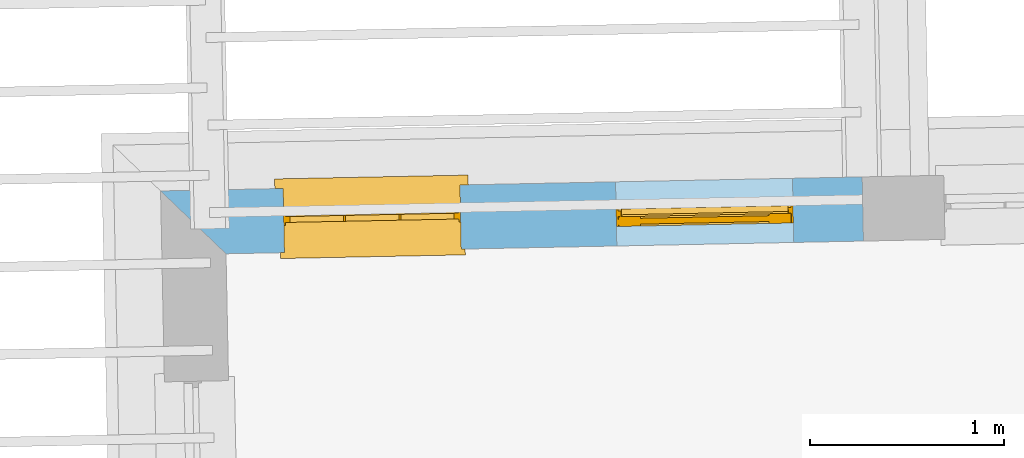
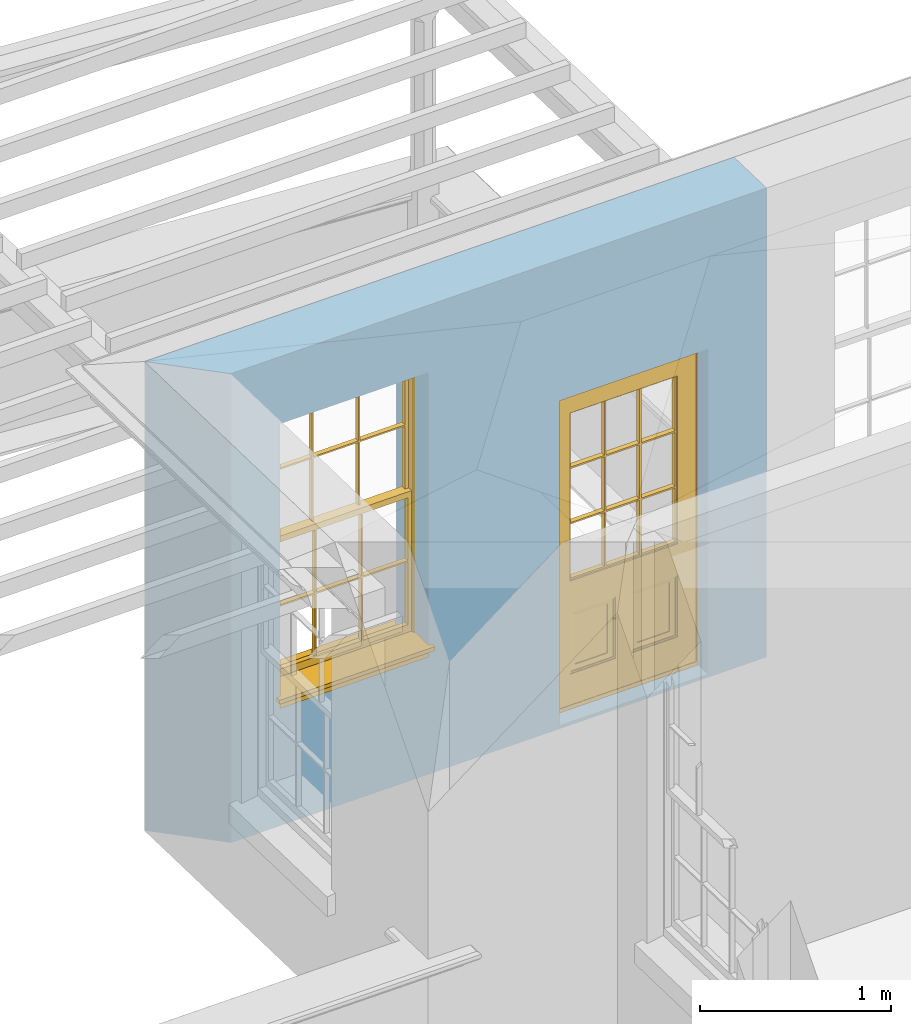
# One storey, part 7 of 11: 1 door, 1 window, 2 openings, plus 1 element that does not belong to this part.
"""IFC2X3 building model written with IfcOpenShell, lengths in metres."""

from ifc_helpers import new_model, si_unit, frame, origin, place, context, subcontext, project, spatial, polyline, outline, extrude, faceted_brep, material, layer, layer_set, layer_usage, element, fill, save


model = new_model("IFC2X3")

# Units and contexts
model_context = context("Model", 3, world=origin())
body_context = subcontext(model_context, "Body", "Model", "MODEL_VIEW")
ifc_project = project(units=[si_unit("PLANEANGLEUNIT", "RADIAN"), si_unit("MASSUNIT", "GRAM", prefix="KILO"), si_unit("FORCEUNIT", "NEWTON", prefix="KILO"), si_unit("LENGTHUNIT", "METRE")], contexts=[model_context])

# Site, building, storey
site_placement = place(None, origin())
site = spatial("IfcSite", under=ifc_project, at=site_placement, CompositionType="ELEMENT")
building_placement = place(None, origin())
building = spatial("IfcBuilding", under=site, at=building_placement, Name="Building plot-11", CompositionType="ELEMENT")
storey_placement = place(None, frame((0.0, 0.0, 5.3)))
storey = spatial("IfcBuildingStorey", under=building, at=storey_placement, Name="Floor 1", CompositionType="ELEMENT", Elevation=5.3)

# Wall, openings, door, window
ifc_material = material(Name="Masonry")
ifc_layer = layer(ifc_material, 0.33, ventilated=False)
ifc_layer_set = layer_set([ifc_layer], Name="My Wall")
ifc_layer_usage = layer_usage(ifc_layer_set, "AXIS2", "NEGATIVE", 0.08)
wall_placement = place(storey_placement, origin())
wall = element("IfcWallStandardCase", 1, at=wall_placement, inside=storey, material=ifc_layer_usage, Name="exterior", context=body_context, shape_type="SweptSolid", body=[
    extrude(outline(polyline([(62.0774340593141, 22.6503225560195), (62.0708365057897, 22.9802565983485), (58.4633191417055, 22.9081185772706), (58.7998507375589, 22.5847820884662), (62.0774340593141, 22.6503225560195)])), origin(), (0.0, 0.0, 1.0), 3.0),
])
opening_1_placement = place(storey_placement, frame((0.0, 0.0, 0.0199999999999996)))
opening_1 = element("IfcOpeningElement", 2, at=opening_1_placement, cuts=wall, Name="Opening", ObjectType="Opening", context=body_context, shape_type="SweptSolid", body=[
    extrude(outline(polyline([(61.7126695585811, 22.9730944831929), (60.802851441856, 22.9549012295347), (60.8094489953804, 22.6249671872058), (61.7192671121056, 22.643160440864), (61.7126695585811, 22.9730944831929)])), origin(), (0.0, 0.0, 1.0), 2.08),
])
opening_2_placement = place(storey_placement, frame((0.0, 0.0, 0.75)))
opening_2 = element("IfcOpeningElement", 3, at=opening_2_placement, cuts=wall, Name="Opening", ObjectType="Opening", context=body_context, shape_type="SweptSolid", body=[
    extrude(outline(polyline([(60.0030113392404, 22.9389071603846), (59.0931932225153, 22.9207139067264), (59.0997907760397, 22.5907798643974), (60.0096088927649, 22.6089731180557), (60.0030113392404, 22.9389071603846)])), origin(), (0.0, 0.0, 1.0), 1.82),
])
door_placement = place(storey_placement, frame((61.7176677051905, 22.7231444511256, 0.0199999999999996), z_axis=(0.0, 0.0, 1.0), x_axis=(-0.90981811672517, -0.0181932536582394, 0.0)))
door = element("IfcDoor", 4, at=door_placement, inside=storey, Name="circulation outside door", OverallHeight=2.08, OverallWidth=0.91, context=body_context, shape_type="Brep", held_by="IfcProductRepresentation", body=[
    faceted_brep([(0.545, -0.055, 0.265), (0.745, -0.055, 0.265), (0.745, -0.05, 0.265), (0.545, -0.05, 0.265), (0.745, -0.05, 0.58), (0.545, -0.05, 0.58), (0.545, -0.055, 0.58), (0.515, -0.06, 0.235), (0.775, -0.06, 0.235), (0.745, -0.055, 0.58), (0.515, -0.06, 0.61), (0.515, -0.065, 0.235), (0.775, -0.065, 0.235), (0.775, -0.06, 0.61), (0.515, -0.065, 0.61), (0.785, -0.065, 0.225), (0.505, -0.065, 0.225), (0.775, -0.065, 0.61), (0.505, -0.065, 0.62), (0.785, -0.065, 0.62), (0.505, -0.07, 0.225), (0.785, -0.07, 0.225), (0.505, -0.07, 0.62), (0.785, -0.07, 0.62), (0.883, -0.07, 0.075), (0.898, -0.07, 0.075), (0.405, -0.07, 0.62), (0.405, -0.07, 0.225), (0.027, -0.07, 0.075), (0.785, -0.07, 0.82), (0.125, -0.07, 0.82), (0.405, -0.065, 0.62), (0.405, -0.065, 0.225), (0.898, -0.07, 2.068), (0.027, -0.08, 0.075), (0.883, -0.08, 0.075), (0.125, -0.07, 0.225), (0.012, -0.07, 0.075), (0.785, -0.06, 0.82), (0.125, -0.06, 0.82), (0.125, -0.07, 0.62), (0.125, -0.065, 0.62), (0.395, -0.065, 0.61), (0.395, -0.065, 0.235), (0.125, -0.065, 0.225), (0.785, -0.07, 1.895), (0.027, -0.11, 0.045), (0.883, -0.11, 0.045), (0.558333, -0.06, 0.83), (0.351667, -0.06, 0.83), (0.125, -0.07, 1.895), (0.125, -0.06, 1.895), (0.785, -0.06, 1.895), (0.012, -0.07, 2.068), (0.135, -0.065, 0.61), (0.395, -0.06, 0.61), (0.395, -0.06, 0.235), (0.135, -0.065, 0.235), (0.027, -0.11, 0.027), (0.883, -0.11, 0.027), (0.568333, -0.06, 0.83), (0.558333, -0.03, 0.83), (0.351667, -0.03, 0.83), (0.341667, -0.06, 0.83), (0.135, -0.06, 1.185), (0.135, -0.06, 1.53), (0.775, -0.06, 1.53), (0.775, -0.06, 1.185), (0.135, -0.06, 0.61), (0.365, -0.055, 0.58), (0.365, -0.055, 0.265), (0.135, -0.06, 0.235), (0.568333, -0.06, 1.175), (0.558333, -0.06, 1.175), (0.775, -0.06, 0.83), (0.558333, -0.03, 1.175), (0.785, -0.03, 0.82), (0.125, -0.03, 0.82), (0.351667, -0.03, 1.175), (0.351667, -0.06, 1.175), (0.341667, -0.06, 1.175), (0.135, -0.06, 0.83), (0.135, -0.06, 1.175), (0.135, -0.03, 1.185), (0.135, -0.03, 1.53), (0.135, -0.06, 1.54), (0.351667, -0.06, 1.885), (0.558333, -0.06, 1.885), (0.775, -0.03, 1.53), (0.775, -0.03, 1.185), (0.775, -0.06, 1.175), (0.775, -0.06, 1.54), (0.165, -0.055, 0.58), (0.365, -0.05, 0.58), (0.365, -0.05, 0.265), (0.165, -0.055, 0.265), (0.568333, -0.03, 0.83), (0.568333, -0.03, 1.175), (0.568333, -0.06, 1.185), (0.558333, -0.06, 1.185), (0.775, -0.03, 0.83), (0.785, -0.02, 0.82), (0.125, -0.02, 0.82), (0.341667, -0.03, 0.83), (0.341667, -0.03, 1.175), (0.351667, -0.06, 1.185), (0.341667, -0.06, 1.185), (0.135, -0.03, 0.83), (0.341667, -0.03, 1.185), (0.125, -0.03, 1.895), (0.341667, -0.03, 1.53), (0.341667, -0.06, 1.53), (0.135, -0.06, 1.885), (0.341667, -0.06, 1.54), (0.341667, -0.06, 1.885), (0.558333, -0.03, 1.885), (0.351667, -0.03, 1.885), (0.568333, -0.06, 1.885), (0.785, -0.03, 1.895), (0.568333, -0.03, 1.185), (0.568333, -0.06, 1.53), (0.568333, -0.03, 1.53), (0.568333, -0.06, 1.54), (0.775, -0.06, 1.885), (0.165, -0.05, 0.58), (0.165, -0.05, 0.265), (0.775, -0.03, 1.175), (0.558333, -0.06, 1.53), (0.351667, -0.03, 1.185), (0.558333, -0.03, 1.185), (0.505, -0.02, 0.62), (0.405, -0.02, 0.62), (0.125, -0.02, 1.895), (0.785, -0.02, 1.895), (0.351667, -0.06, 1.53), (0.135, -0.03, 1.175), (0.135, -0.03, 1.54), (0.341667, -0.03, 1.54), (0.135, -0.03, 1.885), (0.351667, -0.06, 1.54), (0.558333, -0.03, 1.54), (0.558333, -0.06, 1.54), (0.351667, -0.03, 1.54), (0.775, -0.03, 1.54), (0.568333, -0.03, 1.54), (0.775, -0.03, 1.885), (0.558333, -0.03, 1.53), (0.405, -0.02, 0.225), (0.505, -0.02, 0.225), (0.125, -0.02, 0.62), (0.785, -0.02, 0.62), (0.012, -0.02, 2.068), (0.898, -0.02, 2.068), (0.351667, -0.03, 1.53), (0.341667, -0.03, 1.885), (0.568333, -0.03, 1.885), (0.405, -0.025, 0.225), (0.405, -0.025, 0.62), (0.505, -0.025, 0.62), (0.505, -0.025, 0.225), (0.898, -0.02, 0.027), (0.012, -0.02, 0.027), (0.125, -0.025, 0.62), (0.785, -0.025, 0.62), (0.395, -0.025, 0.235), (0.395, -0.025, 0.61), (0.125, -0.02, 0.225), (0.125, -0.025, 0.225), (0.515, -0.025, 0.61), (0.515, -0.025, 0.235), (0.785, -0.02, 0.225), (0.785, -0.025, 0.225), (0.135, -0.025, 0.61), (0.775, -0.025, 0.61), (0.135, -0.025, 0.235), (0.395, -0.03, 0.235), (0.395, -0.03, 0.61), (0.515, -0.03, 0.61), (0.515, -0.03, 0.235), (0.775, -0.025, 0.235), (0.135, -0.03, 0.61), (0.775, -0.03, 0.61), (0.135, -0.03, 0.235), (0.365, -0.035, 0.265), (0.365, -0.035, 0.58), (0.545, -0.035, 0.58), (0.545, -0.035, 0.265), (0.775, -0.03, 0.235), (0.165, -0.035, 0.58), (0.745, -0.035, 0.58), (0.165, -0.035, 0.265), (0.365, -0.04, 0.58), (0.365, -0.04, 0.265), (0.545, -0.04, 0.58), (0.545, -0.04, 0.265), (0.745, -0.035, 0.265), (0.165, -0.04, 0.58), (0.745, -0.04, 0.58), (0.165, -0.04, 0.265), (0.745, -0.04, 0.265), (0.885, -0.072, 0.025), (0.025, -0.072, 0.025), (0.025, -0.1, 0.025), (0.885, -0.1, 0.025), (0.9, -0.02, 0.025), (0.01, -0.02, 0.025), (0.9, -0.072, 0.025), (0.91, -0.02, 0.0), (0.0, -0.02, 0.0), (0.01, -0.072, 0.025), (0.9, -0.072, 2.07), (0.9, -0.02, 2.07), (0.885, -0.072, 2.055), (0.91, -0.02, 2.08), (0.01, -0.02, 2.07), (0.0, -0.02, 2.08), (0.01, -0.072, 2.07), (0.025, -0.072, 2.055), (0.0, -0.15, 2.08), (0.91, -0.15, 2.08), (0.01, -0.15, 2.07), (0.9, -0.15, 2.07), (0.01, -0.1, 2.07), (0.9, -0.1, 2.07), (0.0, -0.15, 0.0), (0.91, -0.15, 0.0), (0.01, -0.15, 0.025), (0.9, -0.15, 0.025), (0.01, -0.1, 0.025), (0.025, -0.1, 2.055), (0.9, -0.1, 0.025), (0.885, -0.1, 2.055), (0.898, -0.07, 0.027), (0.012, -0.07, 0.027), (0.883, -0.07, 0.027), (0.027, -0.07, 0.027)], [[[0, 1, 2, 3]], [[2, 4, 5, 3]], [[0, 3, 5, 6]], [[1, 0, 7, 8]], [[9, 4, 2, 1]], [[9, 6, 5, 4]], [[0, 6, 10, 7]], [[8, 7, 11, 12]], [[8, 13, 9, 1]], [[13, 10, 6, 9]], [[7, 10, 14, 11]], [[15, 12, 11, 16]], [[12, 17, 13, 8]], [[17, 14, 10, 13]], [[18, 16, 11, 14]], [[15, 19, 17, 12]], [[15, 16, 20, 21]], [[14, 17, 19, 18]], [[16, 18, 22, 20]], [[21, 23, 19, 15]], [[24, 25, 21, 20]], [[23, 22, 18, 19]], [[20, 22, 26, 27]], [[23, 21, 25]], [[28, 24, 20, 27]], [[22, 23, 29]], [[29, 30, 26, 22]], [[27, 26, 31, 32]], [[23, 25, 33, 29]], [[34, 35, 24, 28]], [[28, 27, 36, 37]], [[38, 39, 30, 29]], [[26, 30, 40]], [[26, 40, 41, 31]], [[42, 43, 32, 31]], [[32, 44, 36, 27]], [[33, 45, 29]], [[46, 47, 35, 34]], [[36, 40, 37]], [[39, 38, 48, 49]], [[50, 30, 39, 51]], [[29, 45, 52, 38]], [[53, 37, 40, 30]], [[44, 41, 40, 36]], [[31, 41, 54, 42]], [[43, 42, 55, 56]], [[57, 44, 32, 43]], [[50, 45, 33, 53]], [[47, 46, 58, 59]], [[60, 48, 38]], [[49, 48, 61, 62]], [[49, 63, 39]], [[50, 53, 30]], [[51, 39, 64, 65]], [[45, 50, 51, 52]], [[66, 67, 38, 52]], [[57, 54, 41, 44]], [[42, 54, 68, 55]], [[56, 55, 69, 70]], [[56, 71, 57, 43]], [[60, 72, 73, 48]], [[60, 38, 74]], [[48, 73, 75, 61]], [[76, 77, 62, 61]], [[62, 78, 79, 49]], [[49, 79, 80, 63]], [[63, 81, 39]], [[82, 64, 39]], [[65, 64, 83, 84]], [[85, 51, 65]], [[52, 51, 86, 87]], [[88, 89, 67, 66]], [[90, 38, 67]], [[91, 66, 52]], [[71, 68, 54, 57]], [[55, 68, 92, 69]], [[69, 93, 94, 70]], [[70, 95, 71, 56]], [[96, 97, 72, 60]], [[73, 72, 98, 99]], [[74, 38, 90]], [[100, 96, 60, 74]], [[75, 73, 79, 78]], [[61, 75, 97, 96]], [[101, 102, 77, 76]], [[77, 103, 62]], [[96, 76, 61]], [[103, 104, 78, 62]], [[80, 79, 105, 106]], [[63, 80, 104, 103]], [[81, 63, 103, 107]], [[81, 82, 39]], [[106, 64, 82, 80]], [[106, 108, 83, 64]], [[84, 83, 77, 109]], [[110, 111, 65, 84]], [[112, 51, 85]], [[113, 85, 65, 111]], [[114, 86, 51]], [[115, 87, 86, 116]], [[117, 52, 87]], [[118, 76, 89, 88]], [[119, 98, 67, 89]], [[120, 121, 88, 66]], [[67, 98, 72, 90]], [[91, 122, 120, 66]], [[91, 52, 123]], [[95, 92, 68, 71]], [[69, 92, 124, 93]], [[94, 93, 124, 125]], [[94, 125, 95, 70]], [[72, 97, 126, 90]], [[127, 99, 98, 120]], [[99, 105, 79, 73]], [[74, 90, 126, 100]], [[96, 100, 76]], [[128, 129, 75, 78]], [[97, 75, 129, 119]], [[130, 131, 102, 101]], [[109, 77, 102, 132]], [[133, 101, 76, 118]], [[77, 107, 103]], [[78, 104, 108, 128]], [[111, 106, 105, 134]], [[104, 80, 82, 135]], [[107, 135, 82, 81]], [[110, 108, 106, 111]], [[104, 135, 83, 108]], [[83, 135, 77]], [[136, 84, 109]], [[110, 84, 136, 137]], [[114, 51, 112]], [[85, 136, 138, 112]], [[113, 137, 136, 85]], [[111, 134, 139, 113]], [[86, 114, 113, 139]], [[140, 141, 87, 115]], [[139, 142, 116, 86]], [[109, 118, 115, 116]], [[117, 123, 52]], [[117, 87, 141, 122]], [[126, 89, 76]], [[143, 118, 88]], [[120, 98, 119, 121]], [[119, 89, 126, 97]], [[144, 143, 88, 121]], [[144, 122, 91, 143]], [[127, 120, 122, 141]], [[143, 91, 123, 145]], [[124, 92, 95, 125]], [[146, 129, 99, 127]], [[99, 129, 128, 105]], [[100, 126, 76]], [[121, 119, 129, 146]], [[147, 131, 130, 148]], [[131, 149, 102]], [[130, 101, 150]], [[102, 151, 132]], [[118, 109, 132, 133]], [[101, 133, 152]], [[107, 77, 135]], [[153, 128, 108, 110]], [[134, 105, 128, 153]], [[109, 138, 136]], [[153, 110, 137, 142]], [[154, 114, 112, 138]], [[137, 113, 114, 154]], [[141, 139, 134, 127]], [[141, 140, 142, 139]], [[144, 140, 115, 155]], [[142, 137, 154, 116]], [[155, 115, 118]], [[116, 154, 109]], [[117, 155, 145, 123]], [[122, 144, 155, 117]], [[143, 145, 118]], [[121, 146, 140, 144]], [[146, 127, 134, 153]], [[156, 157, 131, 147]], [[148, 130, 158, 159]], [[148, 160, 161, 147]], [[157, 162, 149, 131]], [[161, 151, 102, 149]], [[101, 152, 160, 150]], [[163, 158, 130, 150]], [[151, 152, 133, 132]], [[154, 138, 109]], [[142, 140, 146, 153]], [[145, 155, 118]], [[157, 156, 164, 165]], [[147, 166, 167, 156]], [[168, 169, 159, 158]], [[170, 148, 159, 171]], [[148, 170, 160]], [[166, 147, 161]], [[172, 162, 157, 165]], [[166, 149, 162, 167]], [[166, 161, 149]], [[150, 160, 170]], [[163, 173, 168, 158]], [[171, 163, 150, 170]], [[174, 164, 156, 167]], [[175, 176, 165, 164]], [[169, 168, 177, 178]], [[171, 159, 169, 179]], [[167, 162, 172, 174]], [[176, 180, 172, 165]], [[179, 173, 163, 171]], [[181, 177, 168, 173]], [[164, 174, 182, 175]], [[183, 184, 176, 175]], [[178, 177, 185, 186]], [[179, 169, 178, 187]], [[174, 172, 180, 182]], [[184, 188, 180, 176]], [[187, 181, 173, 179]], [[189, 185, 177, 181]], [[175, 182, 190, 183]], [[191, 184, 183, 192]], [[185, 193, 194, 186]], [[187, 178, 186, 195]], [[182, 180, 188, 190]], [[191, 196, 188, 184]], [[195, 189, 181, 187]], [[197, 193, 185, 189]], [[183, 190, 198, 192]], [[198, 196, 191, 192]], [[194, 193, 197, 199]], [[195, 186, 194, 199]], [[188, 196, 198, 190]], [[197, 189, 195, 199]], [[200, 201, 202, 203]], [[201, 200, 204, 205]], [[206, 204, 200]], [[204, 207, 208, 205]], [[209, 201, 205]], [[210, 211, 204, 206]], [[206, 200, 212, 210]], [[211, 213, 207, 204]], [[214, 205, 208, 215]], [[216, 217, 201, 209]], [[205, 214, 216, 209]], [[216, 214, 211, 210]], [[210, 212, 217, 216]], [[214, 215, 213, 211]], [[218, 219, 213, 215]], [[219, 218, 220, 221]], [[221, 220, 222, 223]], [[215, 208, 224, 218]], [[225, 224, 208, 207]], [[224, 226, 220, 218]], [[224, 225, 227, 226]], [[219, 225, 207, 213]], [[228, 222, 220, 226]], [[219, 221, 227, 225]], [[226, 227, 203, 202]], [[202, 229, 222, 228]], [[228, 226, 202]], [[227, 221, 223, 230]], [[230, 203, 227]], [[217, 229, 202, 201]], [[231, 223, 222, 229]], [[230, 223, 231, 203]], [[231, 229, 217, 212]], [[212, 200, 203, 231]], [[33, 152, 151, 53]], [[25, 160, 152, 33]], [[161, 37, 53, 151]], [[232, 160, 25]], [[161, 233, 37]], [[160, 232, 234]], [[24, 234, 232, 25]], [[233, 161, 235]], [[37, 233, 235, 28]], [[161, 160, 234, 235]], [[35, 47, 234, 24]], [[28, 235, 46, 34]], [[58, 235, 234, 59]], [[59, 234, 47]], [[58, 46, 235]]]),
])
fill(opening_1, door)
window_placement = place(storey_placement, frame((60.0080094858498, 22.6889571283172, 0.75), z_axis=(0.0, 0.0, 1.0), x_axis=(-0.90981811672517, -0.018193253658243, 0.0)))
window = element("IfcWindow", 5, at=window_placement, inside=storey, Name="circulation outside window", OverallHeight=1.82, OverallWidth=0.91, context=body_context, shape_type="Brep", held_by="IfcProductRepresentation", body=[
    faceted_brep([(0.033125, -0.105, 0.975209), (0.01, -0.105, 0.975209), (0.033125, -0.105, 1.376042), (0.876875, -0.105, 0.975209), (0.876875, -0.105, 1.376042), (0.9, -0.105, 0.975209), (0.876875, -0.105, 1.386042), (0.876875, -0.105, 1.786875), (0.9, -0.105, 1.81), (0.033125, -0.105, 1.786875), (0.033125, -0.105, 1.386042), (0.01, -0.105, 1.81), (0.876875, -0.135, 1.376042), (0.876875, -0.135, 0.975209), (0.9, -0.135, 0.937083), (0.033125, -0.135, 1.786875), (0.01, -0.135, 1.81), (0.033125, -0.135, 1.386042), (0.01, -0.135, 0.937083), (0.033125, -0.135, 0.975209), (0.033125, -0.135, 1.376042), (0.876875, -0.135, 1.786875), (0.876875, -0.135, 1.386042), (0.9, -0.135, 1.81), (0.033125, -0.105, 0.937083), (0.01, -0.105, 0.937083), (0.033125, -0.105, 0.53625), (0.876875, -0.105, 0.937083), (0.876875, -0.105, 0.53625), (0.9, -0.105, 0.937083), (0.876875, -0.105, 0.52625), (0.876875, -0.105, 0.125417), (0.9, -0.105, 0.077167), (0.033125, -0.105, 0.125417), (0.033125, -0.105, 0.52625), (0.01, -0.105, 0.077167), (-0.0425, -0.25, 0.01), (-0.0425, -0.3, 0.001667), (0.0, -0.25, 0.01), (0.9525, -0.25, 0.01), (0.91, -0.25, 0.01), (0.9525, -0.3, 0.001667), (-0.02, 0.08, 0.077167), (0.0, 0.08, 0.077167), (-0.02, 0.11, 0.077167), (0.0, -0.06, 0.077167), (0.01, -0.06, 0.077167), (0.91, -0.06, 0.077167), (0.91, 0.08, 0.077167), (0.9, -0.06, 0.077167), (0.93, 0.08, 0.077167), (0.93, 0.11, 0.077167), (0.01, -0.075, 0.975209), (0.9, -0.075, 0.975209), (0.876875, -0.075, 0.125417), (0.876875, -0.075, 0.52625), (0.9, -0.075, 0.077167), (0.876875, -0.075, 0.53625), (0.876875, -0.075, 0.937083), (0.033125, -0.075, 0.125417), (0.01, -0.075, 0.077167), (0.033125, -0.075, 0.52625), (0.033125, -0.075, 0.937083), (0.033125, -0.075, 0.53625), (-0.02, 0.08, 0.052167), (-0.02, 0.11, 0.052167), (0.93, 0.11, 0.052167), (0.93, 0.08, 0.052167), (0.91, 0.08, 0.052167), (0.0, 0.08, 0.052167), (0.91, -0.15, 0.026667), (0.0, -0.15, 0.026667), (-0.0425, -0.3, -0.123333), (0.9525, -0.3, -0.123333), (-0.0425, -0.25, -0.123333), (0.9525, -0.25, -0.123333), (0.01, -0.06, 1.81), (0.9, -0.06, 1.81), (0.0, -0.06, 1.82), (0.91, -0.06, 1.82), (0.01, -0.15, 0.077167), (0.9, -0.15, 0.077167), (0.592292, -0.105, 0.125417), (0.592292, -0.075, 0.125417), (0.317708, -0.075, 0.125417), (0.317708, -0.105, 0.125417), (0.592292, -0.105, 0.53625), (0.317708, -0.105, 0.53625), (0.317708, -0.105, 0.52625), (0.592292, -0.105, 0.52625), (0.592292, -0.075, 0.53625), (0.317708, -0.075, 0.53625), (0.592292, -0.135, 1.386042), (0.592292, -0.105, 1.386042), (0.317708, -0.105, 1.386042), (0.317708, -0.135, 1.386042), (0.317708, -0.135, 1.376042), (0.592292, -0.135, 1.376042), (0.317708, -0.105, 1.376042), (0.592292, -0.105, 1.376042), (0.602292, -0.135, 1.376042), (0.592292, -0.135, 0.975209), (0.602292, -0.135, 0.975209), (0.602292, -0.105, 0.975209), (0.592292, -0.105, 0.975209), (0.602292, -0.105, 1.376042), (0.602292, -0.075, 0.53625), (0.602292, -0.105, 0.53625), (0.317708, -0.075, 0.52625), (0.307708, -0.075, 0.125417), (0.307708, -0.075, 0.52625), (0.602292, -0.075, 0.52625), (0.602292, -0.075, 0.125417), (0.592292, -0.075, 0.52625), (0.307708, -0.075, 0.53625), (0.317708, -0.075, 0.937083), (0.307708, -0.075, 0.937083), (0.602292, -0.075, 0.937083), (0.592292, -0.075, 0.937083), (0.307708, -0.105, 0.52625), (0.307708, -0.105, 0.125417), (0.307708, -0.105, 0.53625), (0.307708, -0.105, 0.937083), (0.592292, -0.105, 0.937083), (0.317708, -0.105, 0.937083), (0.602292, -0.105, 0.937083), (0.602292, -0.105, 0.52625), (0.602292, -0.105, 0.125417), (0.307708, -0.135, 1.386042), (0.307708, -0.135, 1.376042), (0.307708, -0.135, 0.975209), (0.317708, -0.135, 0.975209), (0.317708, -0.135, 1.786875), (0.307708, -0.135, 1.786875), (0.602292, -0.135, 1.786875), (0.592292, -0.135, 1.786875), (0.602292, -0.135, 1.386042), (0.602292, -0.105, 1.386042), (0.307708, -0.105, 1.386042), (0.307708, -0.105, 1.786875), (0.317708, -0.105, 1.786875), (0.592292, -0.105, 1.786875), (0.602292, -0.105, 1.786875), (0.307708, -0.105, 1.376042), (0.317708, -0.105, 0.975209), (0.307708, -0.105, 0.975209), (0.91, -0.15, 1.82), (0.9, -0.15, 1.81), (0.01, -0.15, 1.81), (0.0, -0.15, 1.82), (0.91, -0.25, 0.0), (0.0, -0.25, 0.0), (0.91, 0.08, 0.0), (0.0, 0.08, 0.0)], [[[0, 1, 2]], [[3, 4, 5]], [[6, 7, 8]], [[9, 10, 11]], [[12, 13, 14]], [[15, 16, 17]], [[18, 19, 20]], [[21, 22, 23]], [[24, 25, 26]], [[27, 28, 29]], [[30, 31, 32]], [[33, 34, 35]], [[14, 27, 29]], [[25, 24, 18]], [[36, 37, 38]], [[39, 40, 41]], [[42, 43, 44]], [[45, 46, 43]], [[47, 48, 49]], [[50, 51, 48]], [[1, 0, 52]], [[5, 53, 3]], [[54, 55, 56]], [[57, 58, 53]], [[59, 60, 61]], [[62, 63, 52]], [[48, 43, 46, 49]], [[51, 44, 43, 48]], [[64, 42, 44, 65]], [[65, 44, 51, 66]], [[66, 51, 50, 67]], [[65, 66, 68, 69]], [[60, 56, 49, 46]], [[70, 71, 38, 40]], [[37, 41, 40, 38]], [[37, 72, 73, 41]], [[74, 75, 73, 72]], [[8, 11, 76, 77]], [[76, 78, 79, 77]], [[32, 35, 80, 81]], [[81, 80, 71, 70]], [[82, 83, 84, 85]], [[86, 87, 88, 89]], [[86, 90, 91, 87]], [[92, 93, 94, 95]], [[92, 95, 96, 97]], [[96, 98, 99, 97]], [[100, 97, 101, 102]], [[103, 104, 99, 105]], [[97, 99, 104, 101]], [[102, 103, 105, 100]], [[28, 57, 106, 107]], [[108, 84, 109, 110]], [[111, 112, 83, 113]], [[114, 110, 61, 63]], [[90, 113, 108, 91]], [[115, 91, 114, 116]], [[117, 106, 90, 118]], [[111, 106, 57, 55]], [[119, 110, 109, 120]], [[34, 61, 110, 119]], [[89, 113, 83, 82]], [[88, 108, 113, 89]], [[85, 84, 108, 88]], [[121, 114, 63, 26]], [[122, 116, 114, 121]], [[123, 118, 90, 86]], [[87, 91, 115, 124]], [[107, 106, 117, 125]], [[126, 111, 55, 30]], [[127, 112, 111, 126]], [[126, 30, 28, 107]], [[88, 119, 120, 85]], [[126, 89, 82, 127]], [[125, 123, 86, 107]], [[121, 26, 34, 119]], [[124, 122, 121, 87]], [[128, 17, 20, 129]], [[96, 129, 130, 131]], [[132, 133, 128, 95]], [[134, 135, 92, 136]], [[100, 12, 22, 136]], [[137, 6, 4, 105]], [[94, 138, 139, 140]], [[137, 93, 141, 142]], [[99, 98, 94, 93]], [[143, 2, 10, 138]], [[144, 145, 143, 98]], [[129, 143, 145, 130]], [[20, 2, 143, 129]], [[131, 144, 98, 96]], [[128, 138, 10, 17]], [[133, 139, 138, 128]], [[135, 141, 93, 92]], [[95, 94, 140, 132]], [[22, 6, 137, 136]], [[136, 137, 142, 134]], [[100, 105, 4, 12]], [[107, 86, 89, 126]], [[106, 111, 113, 90]], [[91, 108, 110, 114]], [[87, 121, 119, 88]], [[97, 100, 136, 92]], [[129, 96, 95, 128]], [[98, 143, 138, 94]], [[105, 99, 93, 137]], [[131, 101, 104, 144]], [[124, 115, 118, 123]], [[132, 140, 141, 135]], [[120, 109, 59, 33]], [[15, 9, 139, 133]], [[134, 142, 7, 21]], [[31, 54, 112, 127]], [[36, 74, 72, 37]], [[39, 41, 73, 75]], [[18, 14, 101, 131]], [[23, 16, 132, 135]], [[83, 56, 60, 84]], [[52, 53, 118, 115]], [[53, 52, 144, 104]], [[11, 8, 141, 140]], [[14, 18, 124, 123]], [[2, 1, 11, 10]], [[8, 5, 4, 6]], [[57, 53, 56, 55]], [[60, 52, 63, 61]], [[26, 25, 35, 34]], [[32, 29, 28, 30]], [[14, 23, 22, 12]], [[18, 20, 17, 16]], [[19, 0, 2, 20]], [[17, 10, 9, 15]], [[12, 4, 3, 13]], [[21, 7, 6, 22]], [[27, 58, 57, 28]], [[30, 55, 54, 31]], [[33, 59, 61, 34]], [[26, 63, 62, 24]], [[5, 8, 77, 53]], [[76, 11, 1, 52]], [[46, 45, 78, 76]], [[49, 77, 79, 47]], [[70, 146, 147, 81]], [[71, 80, 148, 149]], [[19, 130, 145, 0]], [[102, 13, 3, 103]], [[116, 122, 24, 62]], [[29, 32, 81, 14]], [[80, 35, 25, 18]], [[60, 46, 76, 52]], [[77, 49, 56, 53]], [[23, 14, 81, 147]], [[16, 148, 80, 18]], [[35, 85, 120]], [[120, 33, 35]], [[127, 82, 32]], [[32, 31, 127]], [[32, 82, 85, 35]], [[102, 101, 14]], [[14, 13, 102]], [[18, 131, 130]], [[130, 19, 18]], [[134, 21, 23]], [[23, 135, 134]], [[16, 15, 133]], [[133, 132, 16]], [[11, 140, 139]], [[139, 9, 11]], [[142, 141, 8]], [[8, 7, 142]], [[23, 147, 148, 16]], [[146, 149, 148, 147]], [[52, 115, 116]], [[116, 62, 52]], [[118, 53, 117]], [[58, 117, 53]], [[27, 125, 117, 58]], [[56, 83, 112]], [[112, 54, 56]], [[109, 84, 60]], [[60, 59, 109]], [[125, 27, 14]], [[14, 123, 125]], [[122, 124, 18]], [[18, 24, 122]], [[145, 144, 52]], [[52, 0, 145]], [[103, 3, 53]], [[53, 104, 103]], [[79, 78, 149, 146]], [[78, 45, 71, 149]], [[146, 70, 47, 79]], [[150, 75, 74, 151]], [[68, 66, 67]], [[48, 68, 67, 50]], [[69, 64, 65]], [[42, 64, 69, 43]], [[69, 68, 152, 153]], [[70, 68, 48, 47]], [[150, 152, 68, 70]], [[43, 69, 71, 45]], [[69, 153, 151, 71]], [[152, 150, 151, 153]], [[38, 151, 74, 36]], [[71, 151, 38]], [[39, 75, 150, 40]], [[40, 150, 70]]]),
])
fill(opening_2, window)

save(model, "model.ifc")
